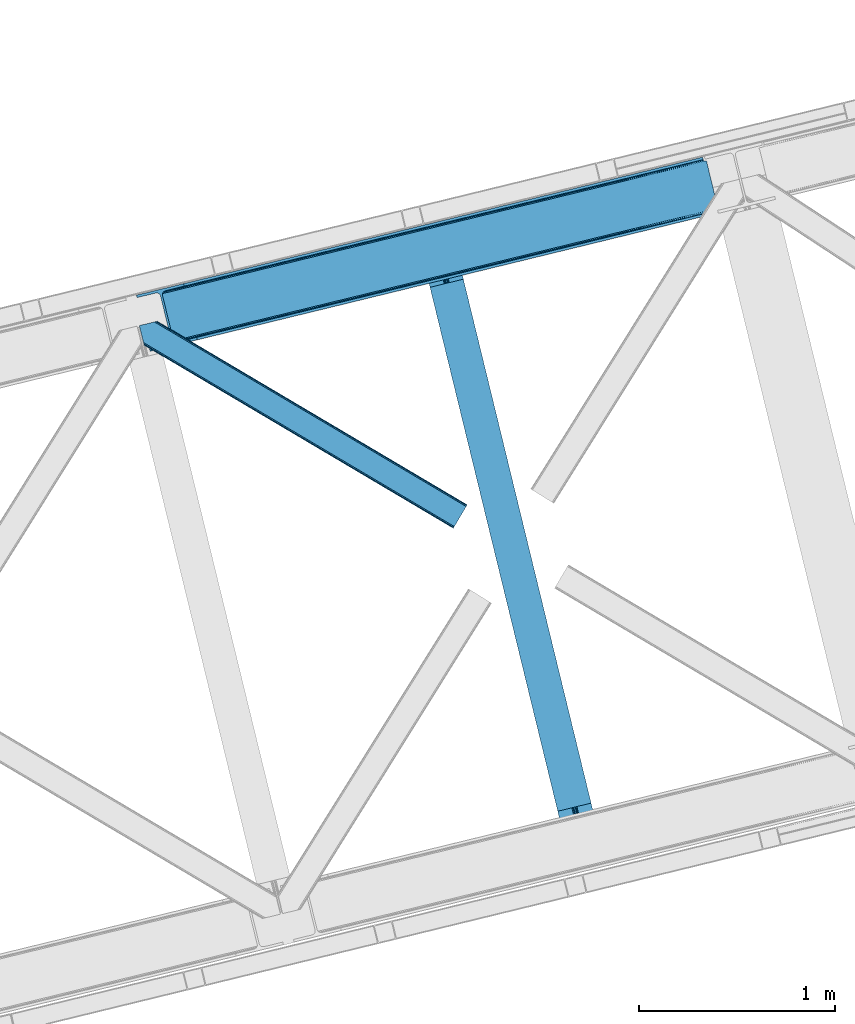
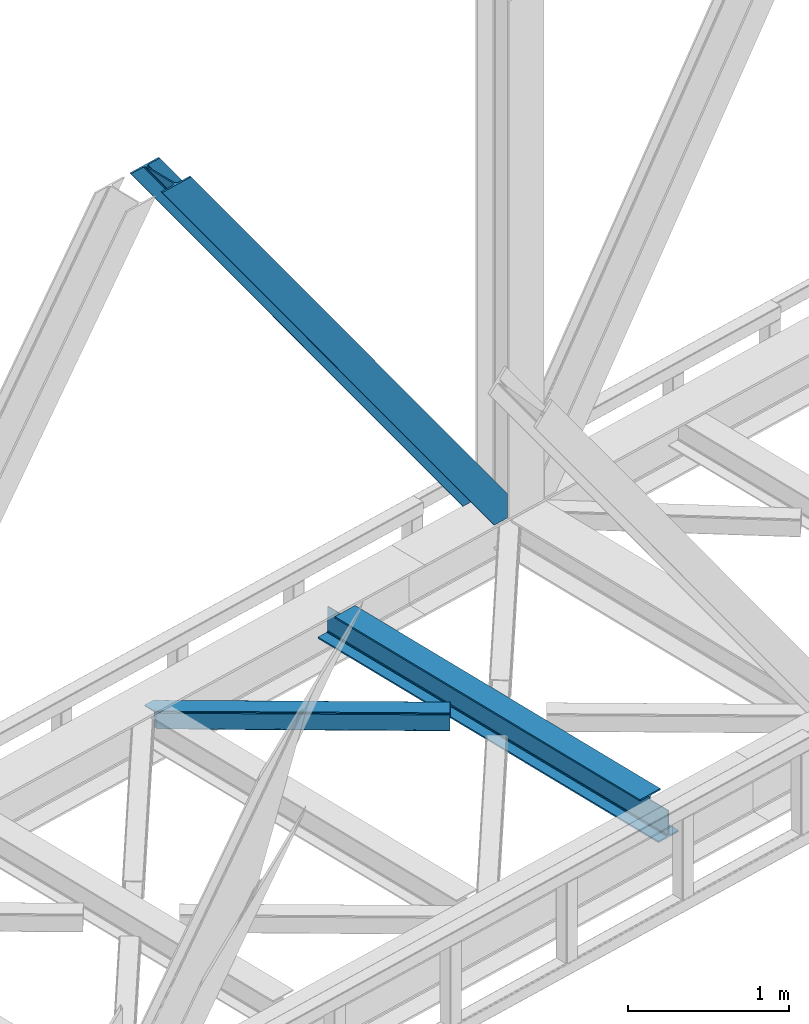
# One storey, part 75 of 93: 2 members, 1 beam.
"""IFC4 building model written with IfcOpenShell, lengths in millimetres."""

from ifc_helpers import new_model, entity, si_unit, converted_unit, derived_unit, direction, frame, origin, place, context, subcontext, project, spatial, triangles, polygons, material, type_object, element, save


model = new_model("IFC4")

# Units and contexts
model_context = context("Model", 3, precision=0.01, world=origin(), true_north=direction((6.12303176911189e-17, 1.0)))
plan_context = context("Plan", 3, precision=0.01, world=origin(), true_north=direction((6.12303176911189e-17, 1.0)))
body_context = subcontext(model_context, "Body", "Model", "MODEL_VIEW")
ifc_project = project(units=[si_unit("LENGTHUNIT", "METRE", prefix="MILLI"), si_unit("AREAUNIT", "SQUARE_METRE"), si_unit("VOLUMEUNIT", "CUBIC_METRE"), converted_unit("PLANEANGLEUNIT", "DEGREE", entity("IfcRatioMeasure", 0.0174532925199433), si_unit("PLANEANGLEUNIT", "RADIAN"), dimensions=[0, 0, 0, 0, 0, 0, 0]), si_unit("MASSUNIT", "GRAM", prefix="KILO"), derived_unit("MASSDENSITYUNIT", [(si_unit("MASSUNIT", "GRAM", prefix="KILO"), 1), (si_unit("LENGTHUNIT", "METRE"), -3)]), derived_unit("MOMENTOFINERTIAUNIT", [(si_unit("LENGTHUNIT", "METRE"), 4)]), si_unit("TIMEUNIT", "SECOND"), si_unit("FREQUENCYUNIT", "HERTZ"), si_unit("THERMODYNAMICTEMPERATUREUNIT", "DEGREE_CELSIUS"), derived_unit("THERMALTRANSMITTANCEUNIT", [(si_unit("MASSUNIT", "GRAM", prefix="KILO"), 1), (si_unit("THERMODYNAMICTEMPERATUREUNIT", "KELVIN"), -1), (si_unit("TIMEUNIT", "SECOND"), -3)]), derived_unit("VOLUMETRICFLOWRATEUNIT", [(si_unit("LENGTHUNIT", "METRE"), 3), (si_unit("TIMEUNIT", "SECOND"), -1)]), derived_unit("MASSFLOWRATEUNIT", [(si_unit("MASSUNIT", "GRAM", prefix="KILO"), 1), (si_unit("TIMEUNIT", "SECOND"), -1)]), derived_unit("ROTATIONALFREQUENCYUNIT", [(si_unit("TIMEUNIT", "SECOND"), -1)]), si_unit("ELECTRICCURRENTUNIT", "AMPERE"), si_unit("ELECTRICVOLTAGEUNIT", "VOLT"), si_unit("POWERUNIT", "WATT"), si_unit("FORCEUNIT", "NEWTON", prefix="KILO"), si_unit("ILLUMINANCEUNIT", "LUX"), si_unit("LUMINOUSFLUXUNIT", "LUMEN"), si_unit("LUMINOUSINTENSITYUNIT", "CANDELA"), derived_unit("USERDEFINED", [(si_unit("MASSUNIT", "GRAM", prefix="KILO"), -1), (si_unit("LENGTHUNIT", "METRE"), -2), (si_unit("TIMEUNIT", "SECOND"), 3), (si_unit("LUMINOUSFLUXUNIT", "LUMEN"), 1)]), derived_unit("LINEARVELOCITYUNIT", [(si_unit("LENGTHUNIT", "METRE"), 1), (si_unit("TIMEUNIT", "SECOND"), -1)]), si_unit("PRESSUREUNIT", "PASCAL"), derived_unit("USERDEFINED", [(si_unit("LENGTHUNIT", "METRE"), -2), (si_unit("MASSUNIT", "GRAM", prefix="KILO"), 1), (si_unit("TIMEUNIT", "SECOND"), -2)]), derived_unit("LINEARFORCEUNIT", [(si_unit("MASSUNIT", "GRAM", prefix="KILO"), 1), (si_unit("LENGTHUNIT", "METRE"), 1), (si_unit("TIMEUNIT", "SECOND"), -2), (si_unit("LENGTHUNIT", "METRE"), -1)]), derived_unit("PLANARFORCEUNIT", [(si_unit("MASSUNIT", "GRAM", prefix="KILO"), 1), (si_unit("LENGTHUNIT", "METRE"), 1), (si_unit("TIMEUNIT", "SECOND"), -2), (si_unit("LENGTHUNIT", "METRE"), -2)])], contexts=[model_context, plan_context])

# Site, building, storey
site_placement = place(None, origin())
site = spatial("IfcSite", under=ifc_project, at=site_placement, CompositionType="ELEMENT")
building_placement = place(site_placement, origin())
building = spatial("IfcBuilding", under=site, at=building_placement, CompositionType="ELEMENT")
storey_placement = place(building_placement, frame((0.0, 0.0, 15900.0)))
storey = spatial("IfcBuildingStorey", under=building, at=storey_placement, CompositionType="ELEMENT", Elevation=15900.0)

# Beam
ifc_material = material(Name="Metal painted (White)")
beam_type = type_object("IfcBeamType", PredefinedType="BEAM")
beam_placement = place(storey_placement, frame((-13358.7328756804, 14538.5967415944, 3441.0)))
element("IfcBeam", 1, at=beam_placement, inside=storey, type_object=beam_type, material=ifc_material, ObjectType="Steel Beam", PredefinedType="BEAM", context=body_context, shape_type="Tessellation", body=[
    polygons([(896.722476515612, 41.4445662733146, 11.000000000004), (896.722476515612, 41.4445662733146, 2.16573425859679e-12), (170.021610174759, 3022.65205668042, 2.16573425859679e-12), (170.021610174759, 3022.65205668042, 11.000000000004), (830.656936561986, 25.3403919499678, 11.000000000004), (103.956070221133, 3006.54788235708, 11.000000000004), (824.708186540696, 23.8903211957396, 12.2179274798217), (98.007320199847, 3005.09781160285, 12.2179274798217), (819.665079784591, 22.6610105689216, 15.6862915010192), (92.9642134437384, 3003.86850097603, 15.6862915010192), (816.295383581416, 21.839611468714, 20.8770650821657), (89.5945172405625, 3003.04710187582, 20.8770650821657), (815.11210363173, 21.5511744621227, 27.0000000000047), (88.4112372908766, 3002.75866486924, 27.0000000000047), (81.6103728838844, 3001.1008822183, 27.0000000000047), (81.6103728838844, 3001.1008822183, 203.000000000006), (88.4112372908744, 3002.75866486923, 203.000000000006), (2.16573425859679e-12, 2981.20749040711, 2.16573425859679e-12), (2.16573425859679e-12, 2981.20749040711, 10.9999999999997), (66.0655399536237, 2997.31166473046, 11.000000000004), (72.0142899749227, 2998.76173548469, 12.2179274798217), (77.0573967310248, 2999.99104611151, 15.6862915010192), (80.4270929341986, 3000.81244521171, 20.8770650821613), (815.112103631725, 21.5511744621227, 203.000000000006), (808.311239224738, 19.8933918111897, 203.000000000006), (808.311239224733, 19.8933918111897, 27.0000000000047), (807.127959275049, 19.6049548046006, 20.8770650821613), (803.758263071878, 18.783555704393, 15.6862915010192), (798.715156315771, 17.554245077575, 12.2179274798217), (792.766406294475, 16.1041743233468, 11.000000000004), (726.700866340851, 2.16573425859679e-12, 10.9999999999997), (726.700866340853, 2.16573425859679e-12, 2.16573425859679e-12), (775.94520191196, 182.229070489532, 203.069792164282), (124.290390378917, 2855.56852806081, 203.000000000006), (124.513271168063, 2854.65418562638, 203.617301946336), (124.526185412587, 2854.60120565348, 217.000003693143), (775.799998669233, 182.824605273258, 217.000003676718), (775.800869277131, 182.821033832379, 204.00000679514), (769.234900758907, 180.199471824632, 203.006342981088), (769.012053092183, 181.11382383896, 203.617301946336), (768.999138847659, 181.166803811851, 217.000003693143), (117.725325591011, 2852.94340419208, 217.000003676718), (117.724454983115, 2852.94697563296, 204.00000679514), (117.580155394062, 2853.53894853353, 203.076120467494), (117.489525971921, 2853.91074540987, 203.000000000006), (776.983483393269, 183.112202246699, 223.122939328039), (780.352479801944, 183.936472070578, 228.313710402595), (785.395115205966, 185.167716295884, 231.782072735464), (791.343694076667, 186.618489150563, 232.999999602236), (857.409144942201, 202.723028934504, 232.999999283132), (857.407671605762, 202.729072911373, 243.999994005812), (687.386290701843, 161.283566114482, 243.999994827032), (687.38776403828, 161.277522137611, 233.000000104353), (753.453214903801, 177.382061921545, 232.999999785253), (759.402120032136, 178.83149638977, 231.782072861012), (764.445684539264, 180.058929212901, 228.313710479427), (767.816071448998, 180.87749487033, 223.12293937232), (116.541840866973, 2852.65580721864, 223.122939328039), (113.172844458302, 2851.83153739476, 228.313710402595), (108.13020905428, 2850.60029316945, 231.782072735464), (102.18163018357, 2849.14952031477, 232.999999602236), (36.1161793180448, 2833.04498053083, 232.999999283128), (36.1176526544845, 2833.03893655396, 243.999994005812), (206.139033558403, 2874.48444335085, 243.999994827032), (206.137560221966, 2874.49048732773, 233.000000104357), (140.072109356436, 2858.38594754379, 232.999999785253), (134.12320422811, 2856.93651307556, 231.782072861012), (129.079639720984, 2855.70908025243, 228.313710479427), (125.709252811243, 2854.890514595, 223.12293937232)], [[[1, 2, 3, 4]], [[5, 1, 4, 6]], [[7, 5, 6, 8]], [[9, 7, 8, 10]], [[11, 9, 10, 12]], [[13, 11, 12, 14]], [[15, 16, 17, 14, 12, 10, 8, 6, 4, 3, 18, 19, 20, 21, 22, 23]], [[13, 24, 25, 26, 27, 28, 29, 30, 31, 32, 2, 1, 5, 7, 9, 11]], [[2, 32, 18, 3]], [[32, 31, 19, 18]], [[31, 30, 20, 19]], [[27, 26, 15, 23]], [[28, 27, 23, 22]], [[29, 28, 22, 21]], [[30, 29, 21, 20]], [[33, 24, 13, 14, 17, 34, 35, 36, 37, 38]], [[25, 39, 40, 41, 42, 43, 44, 16, 15, 26]], [[39, 25, 24, 33]], [[45, 34, 17, 16]], [[41, 40, 38, 37, 46, 47, 48, 49, 50, 51, 52, 53, 54, 55, 56, 57]], [[42, 58, 59, 60, 61, 62, 63, 64, 65, 66, 67, 68, 69, 36, 35, 43]], [[46, 37, 36, 69]], [[47, 46, 69, 68]], [[48, 47, 68, 67]], [[49, 48, 67, 66]], [[50, 49, 66, 65]], [[51, 50, 65, 64]], [[52, 51, 64, 63]], [[53, 52, 63, 62]], [[54, 53, 62, 61]], [[55, 54, 61, 60]], [[56, 55, 60, 59]], [[57, 56, 59, 58]], [[41, 57, 58, 42]]], closed=False),
])

# Members
member_type_1 = type_object("IfcMemberType", PredefinedType="BRACE")
member_1_placement = place(storey_placement, frame((-14820.1128387451, 17045.000289917, 3694.99929199219)))
element("IfcMember", 2, at=member_1_placement, inside=storey, type_object=member_type_1, ObjectType="Steel Vertical Brace", PredefinedType="BRACE", context=body_context, shape_type="Tessellation", body=[
    triangles([(2966.89332275391, 730.998403930666, 0.80925292968459), (2967.55374755859, 730.01590576172, 1.10690917968532), (2966.08058166504, 729.656625366213, 0.0), (2964.18651123047, 737.428244018556, 0.0), (2962.43894348145, 728.768307495116, 8.31577148437282), (2962.43894348145, 728.768307495116, 0.0), (2505.8586730957, 612.605630493166, 658.855133056641), (2511.3606628418, 609.931375122073, 662.301434326171), (2954.04410705566, 717.839904785156, 38.6743835449197), (2954.16968078613, 719.76304321289, 32.1678039550752), (2501.41243286133, 617.533236694337, 656.552947998047), (2958.54266967773, 726.956790161134, 14.8293273925774), (2955.07776489258, 722.24312438965, 26.1867736816384), (2955.64168395996, 723.795355224611, 22.4381652832017), (655.166986083985, 156.054428100586, 3289.34108276367), (649.43826599121, 156.067218017579, 3285.27854003906), (213.883456420897, 48.4865753173835, 3911.00081176758), (205.271191406249, 47.7970825195334, 3911.00081176758), (643.936276245116, 158.7426361084, 3281.83223876953), (197.320513916015, 49.8760253906257, 3911.00081176758), (639.490036010742, 163.669079589843, 3279.53005371094), (191.242977905273, 54.4048187255867, 3911.00081176758), (636.783224487304, 170.100082397461, 3278.7231262207), (187.962945556639, 60.6951324462898, 3911.00081176758), (2954.16154174805, 716.458593750001, 50.6410949707024), (2517.08938293457, 609.917422485352, 666.36397705078), (2051.60849304199, 496.451092529296, 1322.10767211914), (2045.87977294922, 496.465045166016, 1318.04512939453), (1580.39888305664, 382.99871520996, 1973.78882446289), (1586.12760314941, 382.985925292971, 1977.85369262695), (1114.91799316406, 269.533547973635, 2629.53251953125), (1120.64671325684, 269.519595336915, 2633.59738769531), (2040.37778320312, 499.140463256837, 1314.598828125), (1574.89805603027, 385.674133300781, 1970.34484863281), (1109.41716613769, 272.208966064452, 2626.08854370117), (2035.93154296875, 504.066906738281, 1312.29896850586), (1570.45065307617, 390.600576782228, 1968.04266357422), (1104.97092590332, 277.135409545899, 2623.78635864258), (2498.70562133789, 623.963076782227, 655.74602050781), (2033.22473144531, 510.496746826171, 1311.48971557617), (1567.74384155273, 397.031579589846, 1967.23341064453), (1102.26411437988, 283.56524963379, 2622.97710571289), (2909.00615844727, 963.80047302246, 0.0), (2443.52526855469, 850.334143066408, 655.74602050781), (1978.04437866211, 736.868975830079, 1311.48971557617), (1512.56348876953, 623.402645874023, 1967.23341064453), (1047.08376159668, 509.937478637698, 2622.97710571289), (581.602871704101, 396.471148681641, 3278.7231262207), (132.782592773438, 287.06619873047, 3911.00081176758), (307.435885620116, 71.2909973144524, 3911.00081176758), (2954.16154174805, 716.458593750001, 182.433050537107), (2954.35339050293, 715.474932861329, 0.0), (2954.16968078613, 719.76304321289, 0.0), (2954.35339050293, 715.474932861329, 182.495837402341), (2955.64168395996, 723.795355224611, 0.0), (2958.54266967773, 726.956790161134, 0.0), (2957.19507751465, 703.816342163085, 182.495837402341), (310.513604736328, 58.6603729248054, 3911.00081176758), (2957.19507751465, 703.816342163085, 0.0), (2846.09255676269, 676.734274291994, 0.0), (69.8643402099606, 0.0, 3911.00081176758), (2843.01367492676, 689.364898681641, 0.0), (66.7854583740227, 12.6294616699233, 3911.00081176758), (160.337887573241, 35.4338836669922, 3911.00081176758), (2936.56610412598, 712.169320678713, 0.0), (2953.96039123535, 734.936535644531, 0.0), (2953.94295043945, 727.841619873048, 0.0), (177.732174682616, 58.2010986328132, 3911.00081176758), (177.714733886718, 51.1073455810547, 3911.00081176758), (2950.63036193848, 721.023431396487, 0.0), (174.402145385742, 44.2891571044929, 3911.00081176758), (2944.52840881348, 715.520278930664, 0.0), (168.300192260742, 38.7848419189468, 3911.00081176758), (2898.78003845215, 961.307601928711, 0.0), (122.551821899413, 284.573327636721, 3911.00081176758), (2872.85952758789, 973.516159057617, 0.0), (2881.47179260254, 974.205651855471, 0.0), (105.243576049805, 297.47021484375, 3911.00081176758), (96.6313110351548, 296.781884765627, 3911.00081176758), (2889.42130737305, 972.126708984375, 0.0), (113.193090820312, 295.392434692385, 3911.00081176758), (2895.50000610352, 967.597915649414, 0.0), (119.271789550781, 290.863641357424, 3911.00081176758), (3.07888183593604, 273.977462768555, 3911.00081176758), (2779.30709838867, 950.711737060548, 0.0), (2776.22821655273, 963.342361450195, 0.0), (0.0, 286.606924438478, 3911.00081176758), (142.214575195312, 306.482455444337, 3911.00081176758), (150.176879882813, 309.833413696291, 3911.00081176758), (136.111459350584, 300.979302978518, 3911.00081176758), (132.800033569336, 294.161114501952, 3911.00081176758), (240.650427246093, 345.268460083007, 3911.00081176758), (243.729309082031, 332.63783569336, 3911.00081176758), (2887.33073730469, 990.424429321291, 182.495837402341), (2887.33073730469, 990.424429321291, 0.0), (2890.45496520996, 977.805432128906, 182.433050537107), (2890.17358703613, 978.765838623047, 182.495837402341), (1522.42102661133, 644.332763671875, 1977.85369262695), (591.460409545898, 417.401266479494, 3289.34108276367), (1056.94129943848, 530.867596435546, 2633.59738769531), (1987.90191650391, 757.799093627931, 1322.10767211914), (2453.38280639648, 871.26426086426, 666.36397705078), (2890.45496520996, 977.805432128906, 50.6410949707024), (2890.17358703613, 978.765838623047, 0.0), (2890.98749084473, 976.525277709963, 38.6743835449197), (2892.14904785156, 974.998626708984, 33.1630920410134), (2891.98277893066, 974.874215698244, 0.0), (2893.56989135742, 973.138275146484, 26.4425720214822), (2895.14653930664, 971.972067260744, 22.4381652832017), (2903.46928710937, 970.684936523438, 8.31577148437282), (2903.46928710937, 970.684936523438, 0.0), (2899.17652587891, 970.501226806642, 0.0), (2899.17652587891, 970.501226806642, 14.8293273925774), (2895.14653930664, 971.972067260744, 0.0), (2907.11092529297, 971.573254394531, 0.0), (2444.64961853027, 863.708908081055, 658.855133056641), (2442.96948852539, 857.289532470702, 656.552947998047), (2908.44921569824, 970.754699707031, 0.80925292968459), (2908.58409118652, 971.931372070314, 1.10690917968532), (581.047091674804, 403.425375366212, 3279.53005371094), (582.727221679686, 409.845913696288, 3281.83223876953), (586.380487060547, 414.752590942382, 3285.27854003906), (2448.30288391113, 868.615585327148, 662.301434326171), (1977.48859863281, 743.82320251465, 1312.29896850586), (1512.00770874023, 630.358035278321, 1968.04266357422), (1046.52681884766, 516.891705322265, 2623.78635864258), (1979.16872863769, 750.243740844726, 1314.598828125), (1513.68900146484, 636.777410888673, 1970.34484863281), (1048.20811157226, 523.312243652344, 2626.08854370117), (1982.82199401855, 755.15041809082, 1318.04512939453), (1517.3422668457, 641.684088134767, 1973.78882446289), (1051.86137695312, 528.218920898438, 2629.53251953125)], [[1, 2, 3], [3, 4, 1], [2, 5, 6], [6, 3, 2], [7, 8, 9], [9, 10, 7], [11, 12, 5], [5, 1, 11], [11, 7, 13], [13, 14, 11], [14, 12, 11], [15, 16, 17], [18, 17, 16], [16, 19, 18], [20, 18, 19], [19, 21, 20], [22, 20, 21], [21, 23, 22], [24, 22, 23], [5, 2, 1], [10, 13, 7], [25, 9, 8], [8, 26, 25], [26, 8, 27], [28, 27, 8], [27, 28, 29], [29, 30, 27], [30, 29, 31], [31, 32, 30], [32, 31, 16], [16, 15, 32], [8, 7, 33], [33, 28, 8], [28, 33, 34], [34, 29, 28], [29, 34, 31], [35, 31, 34], [31, 35, 16], [19, 16, 35], [7, 11, 33], [36, 33, 11], [33, 36, 34], [37, 34, 36], [34, 37, 35], [38, 35, 37], [35, 38, 21], [21, 19, 35], [1, 4, 11], [39, 11, 4], [11, 39, 36], [40, 36, 39], [36, 40, 37], [41, 37, 40], [37, 41, 38], [42, 38, 41], [38, 42, 21], [23, 21, 42], [4, 43, 44], [45, 39, 44], [41, 40, 45], [41, 45, 46], [44, 39, 4], [45, 40, 39], [42, 41, 46], [46, 47, 42], [47, 48, 23], [49, 24, 48], [47, 23, 42], [48, 24, 23], [50, 51, 30], [30, 32, 50], [32, 15, 50], [17, 50, 15], [27, 30, 51], [51, 25, 26], [26, 27, 51], [52, 9, 25], [52, 53, 10], [10, 9, 52], [25, 51, 54], [54, 52, 25], [14, 53, 55], [53, 14, 13], [10, 53, 13], [56, 12, 55], [14, 55, 12], [6, 5, 56], [12, 56, 5], [57, 54, 58], [54, 51, 50], [50, 58, 54], [57, 59, 52], [52, 54, 57], [58, 60, 57], [58, 61, 60], [60, 59, 57], [62, 60, 63], [61, 63, 60], [63, 64, 62], [65, 62, 64], [66, 67, 68], [69, 68, 67], [67, 70, 69], [71, 69, 70], [70, 72, 71], [73, 71, 72], [72, 65, 73], [64, 73, 65], [74, 66, 75], [68, 75, 66], [76, 77, 78], [78, 79, 76], [77, 80, 81], [81, 78, 77], [80, 82, 83], [83, 81, 80], [82, 74, 75], [75, 83, 82], [79, 84, 85], [85, 76, 79], [86, 85, 87], [84, 87, 85], [75, 68, 49], [71, 73, 18], [64, 61, 17], [63, 61, 64], [73, 64, 17], [68, 69, 22], [69, 71, 20], [81, 88, 78], [87, 79, 89], [79, 78, 89], [87, 84, 79], [81, 83, 90], [83, 75, 91], [49, 68, 24], [17, 18, 73], [22, 69, 20], [18, 20, 71], [22, 24, 68], [58, 17, 61], [58, 50, 17], [89, 78, 88], [90, 83, 91], [49, 91, 75], [90, 88, 81], [89, 92, 87], [92, 89, 93], [92, 86, 87], [86, 92, 94], [95, 86, 94], [96, 97, 93], [97, 94, 92], [92, 93, 97], [98, 96, 93], [93, 99, 100], [99, 93, 89], [100, 98, 93], [96, 98, 101], [101, 102, 96], [103, 96, 102], [97, 104, 94], [95, 94, 104], [104, 105, 106], [96, 103, 97], [104, 97, 103], [103, 105, 104], [107, 108, 109], [107, 106, 108], [110, 111, 112], [112, 113, 110], [113, 112, 114], [114, 109, 113], [109, 114, 107], [106, 107, 104], [53, 70, 55], [76, 86, 95], [85, 86, 76], [77, 76, 95], [104, 80, 77], [77, 95, 104], [104, 107, 80], [60, 65, 59], [52, 72, 70], [65, 72, 59], [60, 62, 65], [70, 53, 52], [52, 59, 72], [43, 66, 74], [82, 112, 74], [80, 114, 82], [80, 107, 114], [82, 114, 112], [111, 43, 74], [112, 111, 74], [43, 111, 115], [4, 66, 43], [56, 66, 6], [55, 70, 67], [67, 66, 56], [56, 55, 67], [4, 6, 66], [3, 6, 4], [116, 113, 109], [117, 118, 113], [113, 116, 117], [109, 108, 116], [118, 119, 110], [110, 113, 118], [48, 120, 91], [91, 49, 48], [120, 121, 90], [90, 91, 120], [121, 122, 88], [88, 90, 121], [122, 99, 89], [89, 88, 122], [105, 103, 123], [102, 123, 103], [106, 116, 108], [116, 106, 105], [123, 116, 105], [43, 118, 44], [117, 44, 118], [44, 117, 124], [124, 45, 44], [45, 124, 125], [125, 46, 45], [46, 125, 126], [126, 47, 46], [47, 126, 120], [120, 48, 47], [117, 116, 127], [127, 124, 117], [124, 127, 128], [128, 125, 124], [125, 128, 129], [129, 126, 125], [126, 129, 121], [121, 120, 126], [116, 123, 127], [130, 127, 123], [127, 130, 128], [131, 128, 130], [128, 131, 132], [132, 129, 128], [129, 132, 122], [122, 121, 129], [123, 102, 101], [101, 130, 123], [130, 101, 131], [98, 131, 101], [131, 98, 132], [100, 132, 98], [132, 100, 122], [99, 122, 100], [110, 119, 111], [115, 111, 119], [119, 118, 115], [43, 115, 118]]),
])
member_type_2 = type_object("IfcMemberType", PredefinedType="BRACE")
member_2_placement = place(storey_placement, frame((-14805.0765472412, 16142.519329834, 3510.00011901855)))
element("IfcMember", 3, at=member_2_placement, inside=storey, type_object=member_type_2, ObjectType="Steel Horizontal Brace", PredefinedType="BRACE", context=body_context, shape_type="Tessellation", body=[
    triangles([(1672.2153717041, 120.471716308593, 122.500662231447), (1672.2153717041, 120.471716308593, 17.5000946044929), (91.5002288818359, 1056.29133911133, 122.500662231447), (91.5002288818359, 1056.29133911133, 17.5000946044929), (1663.30079956055, 105.412170410156, 139.999594116212), (1666.71221923828, 111.175772094726, 138.667117309571), (76.4813781738285, 1052.62993469238, 138.667117309571), (67.1679931640629, 1050.35914306641, 139.999594116212), (1669.60390319824, 116.060357666016, 134.874325561526), (84.3750823974606, 1054.55423583984, 134.874325561526), (1671.53750610352, 119.325274658202, 129.197927856447), (89.6480163574215, 1055.83904113769, 129.197927856447), (18.7674591064442, 956.992749023439, 139.999594116212), (1609.80987854004, 15.0595458984371, 139.999594116212), (0.0, 1033.98688659668, 139.999594116212), (1600.89065551758, 0.0, 122.500662231447), (1601.57317199707, 1.14644165038953, 129.197927856447), (24.5612915039055, 933.226757812501, 122.500662231447), (24.1206207275391, 935.034786987306, 129.197927856447), (1603.50096130371, 4.41019592285193, 134.874325561526), (22.8637207031243, 940.186798095701, 134.874325561526), (1606.3938079834, 9.29594421386719, 138.667117309571), (20.9847656250004, 947.897955322265, 138.667117309571), (1600.89065551758, 0.0, 17.5000946044929), (24.5612915039055, 933.226757812501, 17.5000946044929), (1671.53750610352, 119.325274658202, 10.8028289794929), (89.5619750976566, 1055.81811218262, 10.8167816162131), (162.73657836914, 1012.41959838867, 10.5005218505867), (1669.60390319824, 116.060357666016, 5.12526855468968), (165.152709960938, 1006.73157348633, 5.12526855468968), (164.096960449218, 1011.06270446777, 9.50058288574292), (163.767910766601, 1011.39059143067, 9.74126586914281), (163.419094848632, 1011.74173278808, 10.0005523681648), (163.065628051758, 1012.09287414551, 10.2586761474631), (89.4724456787098, 1055.79602050781, 10.5005218505867), (1666.71221923828, 111.175772094726, 1.33247680664135), (167.031665039061, 999.020416259764, 1.33247680664135), (1663.30079956055, 105.412170410156, 0.0), (169.248971557618, 989.925622558594, 0.0), (1609.80987854004, 15.0595458984371, 0.0), (204.009640502929, 847.325024414064, 0.0), (166.887487792968, 995.390405273438, 10.5005218505867), (72.0351379394524, 1051.54627990722, 10.5005218505867), (168.582733154297, 992.660339355467, 9.50058288574292), (168.16531677246, 993.33355407715, 9.74591674804833), (167.737435913086, 994.026535034178, 10.0005523681648), (167.304904174804, 994.718353271483, 10.2540252685576), (1666.03667907715, 110.036306762695, 12.1260040283232), (1667.9691192627, 113.301223754883, 17.8035644531265), (79.9148895263661, 1053.46709289551, 17.8035644531265), (1663.14383239746, 105.151721191405, 8.3320495605476), (169.397799682616, 989.3175201416, 8.81690368652562), (74.1129180908192, 1052.05206298828, 12.4271484375022), (171.566271972655, 980.419226074218, 6.99957275390625), (1659.73357543945, 99.3892822265625, 6.99957275390625), (1668.64698486328, 114.447665405272, 24.4996673583992), (81.7682647705078, 1053.91822814941, 24.4996673583992), (1668.64698486328, 114.447665405272, 115.501089477541), (81.7682647705078, 1053.91822814941, 115.501089477541), (74.6419555664052, 1052.18112487793, 127.87475280762), (66.7482513427731, 1050.25682373047, 131.667544555665), (79.9148895263661, 1053.46709289551, 122.196029663086), (57.4348663330074, 1047.98719482422, 133.000021362306), (0.0, 1033.98688659668, 133.000021362306), (1667.9691192627, 113.301223754883, 122.196029663086), (1666.03667907715, 110.036306762695, 127.87475280762), (1663.14383239746, 105.151721191405, 131.667544555665), (1659.73357543945, 99.3892822265625, 133.000021362306), (16.4501586914066, 966.499145507811, 133.000021362306), (1613.37245178223, 21.0824340820309, 133.000021362306), (1613.37245178223, 21.0824340820309, 6.99957275390625), (201.692340087891, 856.831420898436, 6.99957275390625), (1607.06934814453, 10.4342468261711, 127.87475280762), (1609.96103210449, 15.3199951171864, 131.667544555665), (1604.45787963867, 6.02405090331922, 115.501089477541), (1605.13574523926, 7.16932983398328, 122.196029663086), (1606.3938079834, 9.29594421386719, 1.33247680664135), (1607.06934814453, 10.4342468261711, 12.1260040283232), (1603.50096130371, 4.41019592285193, 5.12526855468968), (1609.96103210449, 15.3199951171864, 8.3320495605476), (1601.57317199707, 1.14644165038953, 10.8028289794929), (1604.45787963867, 6.02405090331922, 24.4996673583992), (1605.13574523926, 7.16932983398328, 17.8035644531265), (18.6674652099609, 957.404351806641, 131.667544555665), (20.5464202880848, 949.694357299804, 127.87475280762), (21.8033203124996, 944.542346191405, 122.196029663086), (22.2439910888661, 942.733154296873, 115.501089477541), (22.2439910888661, 942.733154296873, 24.4996673583992), (21.7823913574211, 944.627224731446, 17.8163543701194), (21.7602996826172, 944.71675415039, 17.5000946044929), (203.86081237793, 847.933126831054, 8.81690368652562), (206.226947021485, 838.23023071289, 1.33247680664135), (204.67587890625, 844.590307617187, 9.50058288574292), (208.105902099609, 830.520236206054, 5.12526855468968), (209.161651611328, 826.186779785157, 9.50058288574292), (204.68285522461, 843.326431274412, 10.2075164794951), (204.323574829101, 843.305502319336, 10.3540191650391), (203.965457153321, 843.283410644532, 10.5005218505867), (27.0134674072269, 945.867846679686, 12.1260040283232), (28.3459442138665, 947.254971313478, 10.5005218505867), (204.681692504882, 843.958950805665, 9.85404968261719), (32.138735961913, 930.362979125975, 10.8179443359404), (209.134909057617, 825.982141113282, 9.88311767578125), (208.116366577149, 826.255380249024, 10.5005218505867), (208.802371215821, 826.071670532225, 10.0842681884787), (32.4968536376946, 930.225778198243, 10.5005218505867)], [[1, 2, 3], [4, 3, 2], [5, 6, 7], [7, 8, 5], [6, 9, 10], [10, 7, 6], [9, 11, 12], [12, 10, 9], [11, 1, 3], [3, 12, 11], [5, 13, 14], [13, 5, 8], [15, 13, 8], [16, 17, 18], [19, 18, 17], [17, 20, 19], [21, 19, 20], [20, 22, 21], [23, 21, 22], [22, 14, 23], [13, 23, 14], [24, 16, 18], [18, 25, 24], [26, 27, 4], [27, 26, 28], [26, 29, 30], [30, 31, 26], [26, 32, 33], [32, 26, 31], [26, 34, 28], [34, 26, 33], [28, 35, 27], [29, 36, 37], [37, 30, 29], [36, 38, 39], [39, 37, 36], [4, 2, 26], [38, 40, 41], [41, 39, 38], [28, 42, 35], [43, 35, 42], [31, 44, 45], [45, 32, 31], [32, 45, 46], [46, 33, 32], [33, 46, 47], [47, 34, 33], [34, 47, 42], [42, 28, 34], [48, 49, 50], [45, 51, 46], [45, 44, 51], [42, 47, 51], [47, 46, 51], [44, 52, 51], [48, 53, 42], [42, 51, 48], [53, 43, 42], [51, 52, 54], [54, 55, 51], [50, 53, 48], [49, 56, 57], [57, 50, 49], [56, 58, 59], [59, 57, 56], [60, 61, 7], [10, 60, 7], [10, 12, 62], [60, 10, 62], [62, 12, 3], [61, 8, 7], [15, 63, 64], [15, 8, 63], [61, 63, 8], [62, 3, 59], [57, 4, 50], [3, 57, 59], [4, 27, 50], [3, 4, 57], [35, 50, 27], [35, 53, 50], [35, 43, 53], [58, 65, 59], [62, 59, 65], [65, 66, 62], [60, 62, 66], [66, 67, 60], [61, 60, 67], [67, 68, 61], [63, 61, 68], [68, 69, 63], [68, 70, 69], [69, 64, 63], [71, 55, 72], [54, 72, 55], [11, 66, 65], [58, 2, 1], [11, 65, 1], [11, 9, 66], [65, 58, 1], [66, 9, 6], [68, 5, 14], [5, 67, 6], [67, 5, 68], [67, 66, 6], [26, 48, 29], [56, 2, 58], [2, 49, 26], [49, 2, 56], [26, 49, 48], [38, 55, 40], [36, 29, 48], [48, 51, 36], [51, 55, 38], [38, 36, 51], [73, 22, 20], [14, 70, 68], [14, 74, 70], [74, 14, 22], [73, 74, 22], [75, 16, 24], [17, 76, 73], [20, 17, 73], [76, 17, 16], [75, 76, 16], [77, 78, 79], [40, 55, 71], [71, 80, 40], [80, 78, 77], [77, 40, 80], [81, 79, 78], [24, 82, 75], [83, 24, 81], [24, 83, 82], [83, 81, 78], [70, 74, 84], [84, 69, 70], [74, 73, 85], [85, 84, 74], [73, 76, 86], [86, 85, 73], [76, 75, 87], [87, 86, 76], [75, 82, 87], [88, 87, 82], [86, 87, 18], [18, 19, 86], [21, 86, 19], [86, 21, 85], [18, 88, 25], [89, 90, 25], [25, 88, 89], [87, 88, 18], [84, 23, 13], [15, 69, 13], [64, 69, 15], [84, 85, 23], [23, 85, 21], [69, 84, 13], [44, 30, 37], [39, 44, 37], [54, 52, 39], [54, 39, 72], [30, 44, 31], [39, 52, 44], [72, 41, 91], [41, 92, 93], [41, 72, 39], [94, 93, 92], [41, 93, 91], [94, 95, 93], [83, 89, 88], [71, 72, 91], [78, 96, 97], [97, 98, 78], [98, 99, 78], [98, 100, 99], [80, 91, 93], [93, 78, 80], [78, 93, 101], [101, 96, 78], [83, 78, 99], [99, 90, 83], [90, 89, 83], [91, 80, 71], [88, 82, 83], [24, 25, 102], [79, 103, 95], [81, 102, 104], [104, 79, 81], [104, 105, 79], [95, 94, 79], [40, 77, 92], [92, 41, 40], [77, 79, 94], [94, 92, 77], [106, 81, 24], [99, 106, 25], [99, 100, 106], [25, 90, 99], [98, 104, 106], [106, 100, 98]]),
])

save(model, "model.ifc")
